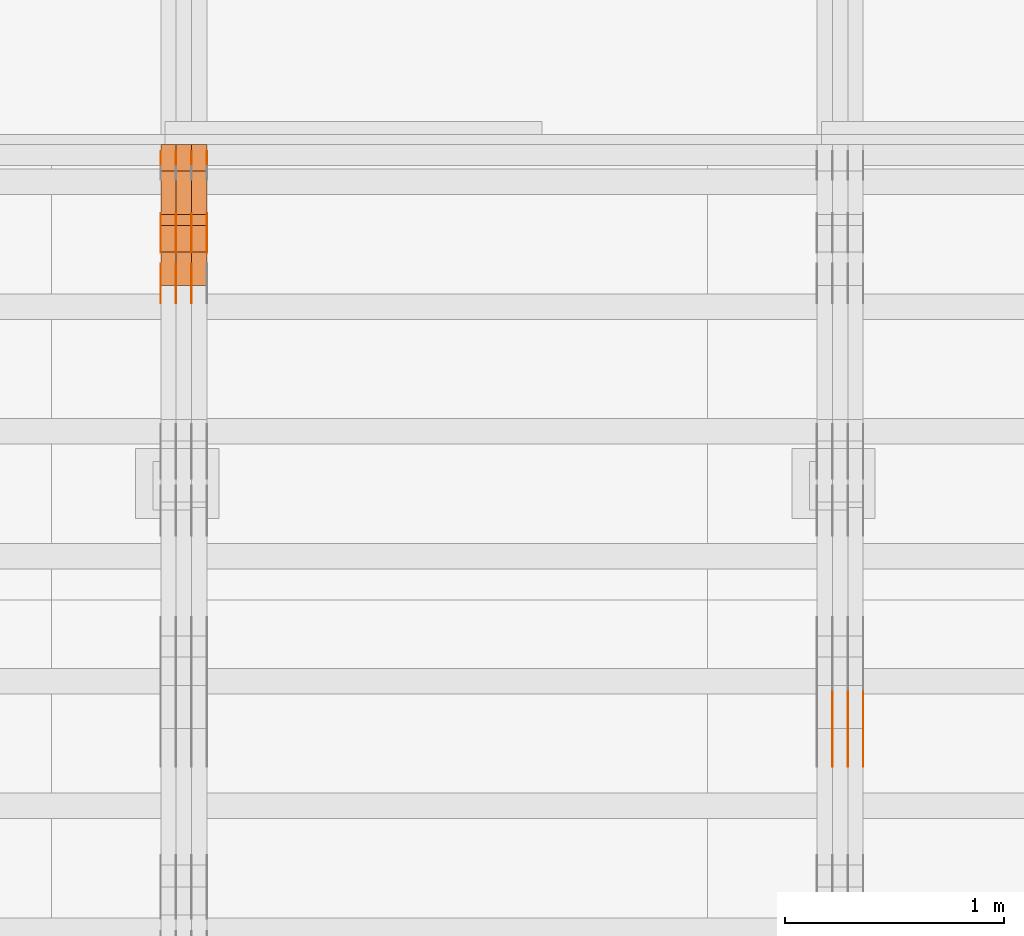
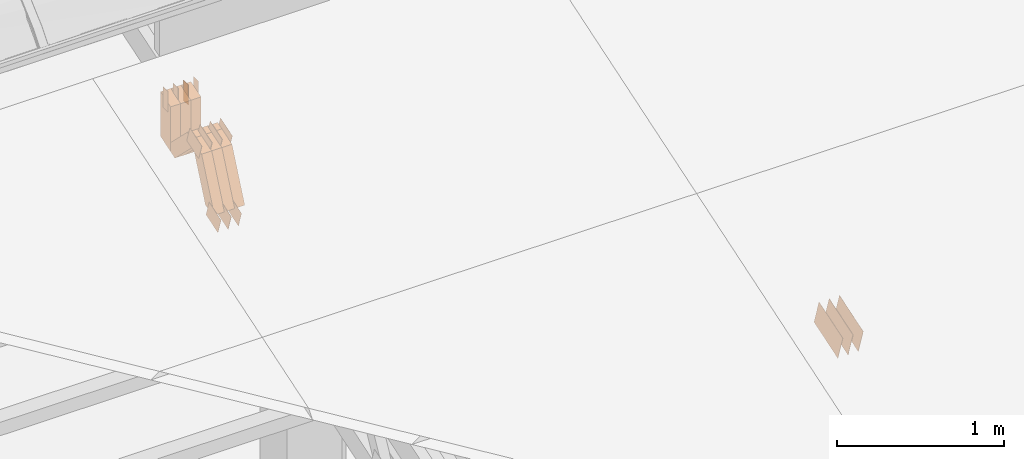
# One storey, part 296 of 385: 29 proxies.
"""IFC2X3 building model written with IfcOpenShell, lengths in millimetres."""

from ifc_helpers import new_model, entity, si_unit, converted_unit, derived_unit, direction, frame, origin, origin_2d_with_axis, place, context, subcontext, project, spatial, polyline, rectangle, outline, extrude, source, transform, mapped, material, type_object, type_shapes, element, save


model = new_model("IFC2X3")

# Units and contexts
model_context = context("Model", 3, precision=0.01, world=origin(), true_north=direction((6.12303176911189e-17, 1.0)))
body_context = subcontext(model_context, "Body", "Model", "MODEL_VIEW")
ifc_project = project(units=[si_unit("LENGTHUNIT", "METRE", prefix="MILLI"), si_unit("AREAUNIT", "SQUARE_METRE"), si_unit("VOLUMEUNIT", "CUBIC_METRE"), converted_unit("PLANEANGLEUNIT", "DEGREE", entity("IfcRatioMeasure", 0.0174532925199433), si_unit("PLANEANGLEUNIT", "RADIAN"), dimensions=[0, 0, 0, 0, 0, 0, 0]), si_unit("MASSUNIT", "GRAM", prefix="KILO"), derived_unit("MASSDENSITYUNIT", [(si_unit("MASSUNIT", "GRAM", prefix="KILO"), 1), (si_unit("LENGTHUNIT", "METRE"), -3)]), si_unit("TIMEUNIT", "SECOND"), si_unit("FREQUENCYUNIT", "HERTZ"), si_unit("THERMODYNAMICTEMPERATUREUNIT", "DEGREE_CELSIUS"), derived_unit("THERMALTRANSMITTANCEUNIT", [(si_unit("MASSUNIT", "GRAM", prefix="KILO"), 1), (si_unit("THERMODYNAMICTEMPERATUREUNIT", "KELVIN"), -1), (si_unit("TIMEUNIT", "SECOND"), -3)]), derived_unit("VOLUMETRICFLOWRATEUNIT", [(si_unit("LENGTHUNIT", "METRE"), 3), (si_unit("TIMEUNIT", "SECOND"), -1)]), si_unit("ELECTRICCURRENTUNIT", "AMPERE"), si_unit("ELECTRICVOLTAGEUNIT", "VOLT"), si_unit("POWERUNIT", "WATT"), si_unit("FORCEUNIT", "NEWTON", prefix="KILO"), si_unit("ILLUMINANCEUNIT", "LUX"), si_unit("LUMINOUSFLUXUNIT", "LUMEN"), si_unit("LUMINOUSINTENSITYUNIT", "CANDELA"), derived_unit("USERDEFINED", [(si_unit("MASSUNIT", "GRAM", prefix="KILO"), -1), (si_unit("LENGTHUNIT", "METRE"), -2), (si_unit("TIMEUNIT", "SECOND"), 3), (si_unit("LUMINOUSFLUXUNIT", "LUMEN"), 1)]), derived_unit("LINEARVELOCITYUNIT", [(si_unit("LENGTHUNIT", "METRE"), 1), (si_unit("TIMEUNIT", "SECOND"), -1)]), si_unit("PRESSUREUNIT", "PASCAL"), derived_unit("USERDEFINED", [(si_unit("LENGTHUNIT", "METRE"), -2), (si_unit("MASSUNIT", "GRAM", prefix="KILO"), 1), (si_unit("TIMEUNIT", "SECOND"), -2)])], contexts=[model_context])

# Site, building, storey
site_placement = place(None, origin())
site = spatial("IfcSite", under=ifc_project, at=site_placement, CompositionType="ELEMENT")
building_placement = place(site_placement, origin())
building = spatial("IfcBuilding", under=site, at=building_placement, CompositionType="ELEMENT")
storey_placement = place(building_placement, origin())
storey = spatial("IfcBuildingStorey", under=building, at=storey_placement, Name="Default", CompositionType="ELEMENT", Elevation=0.0)

# Proxies
ifc_material_1 = material(Name="IfcSurfaceStyle #552776")
building_element_proxy_type_1 = type_object("IfcBuildingElementProxyType", PredefinedType="NOTDEFINED", material=ifc_material_1)
shared_shape_1 = source(origin(), body_context, "Body", "SweptSolid", [
    extrude(outline(polyline([(-149.99966632326, -95.9999759039407), (149.999881095801, -95.9999759039407), (150.000557367591, 95.9999759039407), (-150.000772140132, 95.9999759039406), (-149.99966632326, -95.9999759039407)])), frame((150.000557367591, 96.0004291135906, 0.0), z_axis=(0.0, 0.0, 1.0), x_axis=(-1.0, 0.0, 0.0)), (0.0, 0.0, 1.0), 1.29999999999999),
])
type_shapes(building_element_proxy_type_1, [shared_shape_1])
proxy_1_placement = place(building_placement, frame((45386.3, 10934.7734375, 2766.8759765625), z_axis=(-1.0, 0.0, 0.0), x_axis=(0.0, 0.951056516295124, 0.309016994375039)))
element("IfcBuildingElementProxy", 1, at=proxy_1_placement, inside=storey, type_object=building_element_proxy_type_1, material=ifc_material_1, context=body_context, shape_type="MappedRepresentation", body=[
    mapped(shared_shape_1, transform((0.0, 0.0, 0.0), scale=1.0)),
])
ifc_material_2 = material(Name="IfcSurfaceStyle #552719")
building_element_proxy_type_2 = type_object("IfcBuildingElementProxyType", PredefinedType="NOTDEFINED", material=ifc_material_2)
shared_shape_2 = source(origin(), body_context, "Body", "SweptSolid", [
    extrude(outline(polyline([(-149.99966632326, -95.9999759039407), (149.999881095801, -95.9999759039407), (150.000557367591, 95.9999759039407), (-150.000772140132, 95.9999759039406), (-149.99966632326, -95.9999759039407)])), frame((150.000557367591, 96.0004291135906, 0.0), z_axis=(0.0, 0.0, 1.0), x_axis=(-1.0, 0.0, 0.0)), (0.0, 0.0, 1.0), 1.29999999999999),
])
type_shapes(building_element_proxy_type_2, [shared_shape_2])
proxy_2_placement = place(building_placement, frame((45315.0, 10934.7734375, 2766.8759765625), z_axis=(-1.0, 0.0, 0.0), x_axis=(0.0, 0.951056516295124, 0.309016994375039)))
element("IfcBuildingElementProxy", 2, at=proxy_2_placement, inside=storey, type_object=building_element_proxy_type_2, material=ifc_material_2, context=body_context, shape_type="MappedRepresentation", body=[
    mapped(shared_shape_2, transform((0.0, 0.0, 0.0), scale=1.0)),
])
ifc_material_3 = material(Name="IfcSurfaceStyle #552662")
building_element_proxy_type_3 = type_object("IfcBuildingElementProxyType", PredefinedType="NOTDEFINED", material=ifc_material_3)
shared_shape_3 = source(origin(), body_context, "Body", "SweptSolid", [
    extrude(outline(polyline([(-149.99966632326, -95.9999759039407), (149.999881095801, -95.9999759039407), (150.000557367591, 95.9999759039407), (-150.000772140132, 95.9999759039406), (-149.99966632326, -95.9999759039407)])), frame((150.000557367591, 96.0004291135906, 0.0), z_axis=(0.0, 0.0, 1.0), x_axis=(-1.0, 0.0, 0.0)), (0.0, 0.0, 1.0), 1.29999999999999),
])
type_shapes(building_element_proxy_type_3, [shared_shape_3])
proxy_3_placement = place(building_placement, frame((45316.3, 10934.7734375, 2766.8759765625), z_axis=(-1.0, 0.0, 0.0), x_axis=(0.0, 0.951056516295124, 0.309016994375039)))
element("IfcBuildingElementProxy", 3, at=proxy_3_placement, inside=storey, type_object=building_element_proxy_type_3, material=ifc_material_3, context=body_context, shape_type="MappedRepresentation", body=[
    mapped(shared_shape_3, transform((0.0, 0.0, 0.0), scale=1.0)),
])
ifc_material_4 = material(Name="IfcSurfaceStyle #552605")
building_element_proxy_type_4 = type_object("IfcBuildingElementProxyType", PredefinedType="NOTDEFINED", material=ifc_material_4)
shared_shape_4 = source(origin(), body_context, "Body", "SweptSolid", [
    extrude(outline(polyline([(-149.99966632326, -95.9999759039407), (149.999881095801, -95.9999759039407), (150.000557367591, 95.9999759039407), (-150.000772140132, 95.9999759039406), (-149.99966632326, -95.9999759039407)])), frame((150.000557367591, 96.0004291135906, 0.0), z_axis=(0.0, 0.0, 1.0), x_axis=(-1.0, 0.0, 0.0)), (0.0, 0.0, 1.0), 1.29999999999998),
])
type_shapes(building_element_proxy_type_4, [shared_shape_4])
proxy_4_placement = place(building_placement, frame((45245.0, 10934.7734375, 2766.8759765625), z_axis=(-1.0, 0.0, 0.0), x_axis=(0.0, 0.951056516295124, 0.309016994375039)))
element("IfcBuildingElementProxy", 4, at=proxy_4_placement, inside=storey, type_object=building_element_proxy_type_4, material=ifc_material_4, context=body_context, shape_type="MappedRepresentation", body=[
    mapped(shared_shape_4, transform((0.0, 0.0, 0.0), scale=1.0)),
])
ifc_material_5 = material(Name="IfcSurfaceStyle #518572")
building_element_proxy_type_5 = type_object("IfcBuildingElementProxyType", PredefinedType="NOTDEFINED", material=ifc_material_5)
shared_shape_5 = source(origin(), body_context, "Body", "SweptSolid", [
    extrude(outline(polyline([(-75.0003398116828, -59.9998507501386), (75.0003249421766, -59.9998507501386), (75.0003398116837, 59.9998507501387), (-75.0003249421775, 59.9998507501387), (-75.0003398116828, -59.9998507501386)])), frame((75.0003398116837, 60.0000773549637, 0.0), z_axis=(0.0, 0.0, 1.0), x_axis=(-1.0, 0.0, 0.0)), (0.0, 0.0, 1.0), 1.3),
])
type_shapes(building_element_proxy_type_5, [shared_shape_5])
proxy_5_placement = place(building_placement, frame((42316.3, 13054.73046875, 3417.8388671875), z_axis=(-1.0, 0.0, 0.0), x_axis=(0.0, 0.951056516295124, 0.309016994375039)))
element("IfcBuildingElementProxy", 5, at=proxy_5_placement, inside=storey, type_object=building_element_proxy_type_5, material=ifc_material_5, context=body_context, shape_type="MappedRepresentation", body=[
    mapped(shared_shape_5, transform((0.0, 0.0, 0.0), scale=1.0)),
])
ifc_material_6 = material(Name="IfcSurfaceStyle #518515")
building_element_proxy_type_6 = type_object("IfcBuildingElementProxyType", PredefinedType="NOTDEFINED", material=ifc_material_6)
shared_shape_6 = source(origin(), body_context, "Body", "SweptSolid", [
    extrude(outline(polyline([(-75.0003398116828, -59.9998507501386), (75.0003249421766, -59.9998507501386), (75.0003398116837, 59.9998507501387), (-75.0003249421775, 59.9998507501387), (-75.0003398116828, -59.9998507501386)])), frame((75.0003398116837, 60.0000773549637, 0.0), z_axis=(0.0, 0.0, 1.0), x_axis=(-1.0, 0.0, 0.0)), (0.0, 0.0, 1.0), 1.29999999999999),
])
type_shapes(building_element_proxy_type_6, [shared_shape_6])
proxy_6_placement = place(building_placement, frame((42245.0, 13054.73046875, 3417.8388671875), z_axis=(-1.0, 0.0, 0.0), x_axis=(0.0, 0.951056516295124, 0.309016994375039)))
element("IfcBuildingElementProxy", 6, at=proxy_6_placement, inside=storey, type_object=building_element_proxy_type_6, material=ifc_material_6, context=body_context, shape_type="MappedRepresentation", body=[
    mapped(shared_shape_6, transform((0.0, 0.0, 0.0), scale=1.0)),
])
ifc_material_7 = material(Name="IfcSurfaceStyle #518458")
building_element_proxy_type_7 = type_object("IfcBuildingElementProxyType", PredefinedType="NOTDEFINED", material=ifc_material_7)
shared_shape_7 = source(origin(), body_context, "Body", "SweptSolid", [
    extrude(outline(polyline([(-75.0003398116828, -59.9998507501386), (75.0003249421766, -59.9998507501386), (75.0003398116837, 59.9998507501387), (-75.0003249421775, 59.9998507501387), (-75.0003398116828, -59.9998507501386)])), frame((75.0003398116837, 60.0000773549637, 0.0), z_axis=(0.0, 0.0, 1.0), x_axis=(-1.0, 0.0, 0.0)), (0.0, 0.0, 1.0), 1.29999999999999),
])
type_shapes(building_element_proxy_type_7, [shared_shape_7])
proxy_7_placement = place(building_placement, frame((42246.3, 13054.73046875, 3417.8388671875), z_axis=(-1.0, 0.0, 0.0), x_axis=(0.0, 0.951056516295124, 0.309016994375039)))
element("IfcBuildingElementProxy", 7, at=proxy_7_placement, inside=storey, type_object=building_element_proxy_type_7, material=ifc_material_7, context=body_context, shape_type="MappedRepresentation", body=[
    mapped(shared_shape_7, transform((0.0, 0.0, 0.0), scale=1.0)),
])
ifc_material_8 = material(Name="IfcSurfaceStyle #518401")
building_element_proxy_type_8 = type_object("IfcBuildingElementProxyType", PredefinedType="NOTDEFINED", material=ifc_material_8)
shared_shape_8 = source(origin(), body_context, "Body", "SweptSolid", [
    extrude(outline(polyline([(-75.0003398116828, -59.9998507501386), (75.0003249421766, -59.9998507501386), (75.0003398116837, 59.9998507501387), (-75.0003249421775, 59.9998507501387), (-75.0003398116828, -59.9998507501386)])), frame((75.0003398116837, 60.0000773549637, 0.0), z_axis=(0.0, 0.0, 1.0), x_axis=(-1.0, 0.0, 0.0)), (0.0, 0.0, 1.0), 1.29999999999999),
])
type_shapes(building_element_proxy_type_8, [shared_shape_8])
proxy_8_placement = place(building_placement, frame((42175.0, 13054.73046875, 3417.8388671875), z_axis=(-1.0, 0.0, 0.0), x_axis=(0.0, 0.951056516295124, 0.309016994375039)))
element("IfcBuildingElementProxy", 8, at=proxy_8_placement, inside=storey, type_object=building_element_proxy_type_8, material=ifc_material_8, context=body_context, shape_type="MappedRepresentation", body=[
    mapped(shared_shape_8, transform((0.0, 0.0, 0.0), scale=1.0)),
])
ifc_material_9 = material(Name="IfcSurfaceStyle #510820")
building_element_proxy_type_9 = type_object("IfcBuildingElementProxyType", PredefinedType="NOTDEFINED", material=ifc_material_9)
shared_shape_9 = source(origin(), body_context, "Body", "SweptSolid", [
    extrude(outline(polyline([(-74.999875428623, -60.0000016373506), (74.9998605591059, -60.0000016373506), (74.9998754286239, 60.0000016373506), (-74.9998605591068, 60.0000016373506), (-74.999875428623, -60.0000016373506)])), frame((75.0002691827262, 60.0000190504561, 0.0), z_axis=(0.0, 0.0, 1.0), x_axis=(-1.0, 0.0, 0.0)), (0.0, 0.0, 1.0), 1.3),
])
type_shapes(building_element_proxy_type_9, [shared_shape_9])
proxy_9_placement = place(building_placement, frame((42386.3, 13285.0865109705, 3819.37496637467), z_axis=(-1.0, 0.0, 0.0), x_axis=(0.0, 0.951056516295154, 0.309016994374948)))
element("IfcBuildingElementProxy", 9, at=proxy_9_placement, inside=storey, type_object=building_element_proxy_type_9, material=ifc_material_9, context=body_context, shape_type="MappedRepresentation", body=[
    mapped(shared_shape_9, transform((0.0, 0.0, 0.0), scale=1.0)),
])
ifc_material_10 = material(Name="IfcSurfaceStyle #510763")
building_element_proxy_type_10 = type_object("IfcBuildingElementProxyType", PredefinedType="NOTDEFINED", material=ifc_material_10)
shared_shape_10 = source(origin(), body_context, "Body", "SweptSolid", [
    extrude(outline(polyline([(-74.999875428623, -60.0000016373506), (74.9998605591059, -60.0000016373506), (74.9998754286239, 60.0000016373506), (-74.9998605591068, 60.0000016373506), (-74.999875428623, -60.0000016373506)])), frame((75.0002691827262, 60.0000190504561, 0.0), z_axis=(0.0, 0.0, 1.0), x_axis=(-1.0, 0.0, 0.0)), (0.0, 0.0, 1.0), 1.3),
])
type_shapes(building_element_proxy_type_10, [shared_shape_10])
proxy_10_placement = place(building_placement, frame((42315.0, 13285.0865109705, 3819.37496637467), z_axis=(-1.0, 0.0, 0.0), x_axis=(0.0, 0.951056516295154, 0.309016994374948)))
element("IfcBuildingElementProxy", 10, at=proxy_10_placement, inside=storey, type_object=building_element_proxy_type_10, material=ifc_material_10, context=body_context, shape_type="MappedRepresentation", body=[
    mapped(shared_shape_10, transform((0.0, 0.0, 0.0), scale=1.0)),
])
ifc_material_11 = material(Name="IfcSurfaceStyle #510706")
building_element_proxy_type_11 = type_object("IfcBuildingElementProxyType", PredefinedType="NOTDEFINED", material=ifc_material_11)
shared_shape_11 = source(origin(), body_context, "Body", "SweptSolid", [
    extrude(outline(polyline([(-74.999875428623, -60.0000016373506), (74.9998605591059, -60.0000016373506), (74.9998754286239, 60.0000016373506), (-74.9998605591068, 60.0000016373506), (-74.999875428623, -60.0000016373506)])), frame((75.0002691827262, 60.0000190504561, 0.0), z_axis=(0.0, 0.0, 1.0), x_axis=(-1.0, 0.0, 0.0)), (0.0, 0.0, 1.0), 1.3),
])
type_shapes(building_element_proxy_type_11, [shared_shape_11])
proxy_11_placement = place(building_placement, frame((42316.3, 13285.0865109705, 3819.37496637467), z_axis=(-1.0, 0.0, 0.0), x_axis=(0.0, 0.951056516295154, 0.309016994374948)))
element("IfcBuildingElementProxy", 11, at=proxy_11_placement, inside=storey, type_object=building_element_proxy_type_11, material=ifc_material_11, context=body_context, shape_type="MappedRepresentation", body=[
    mapped(shared_shape_11, transform((0.0, 0.0, 0.0), scale=1.0)),
])
ifc_material_12 = material(Name="IfcSurfaceStyle #510649")
building_element_proxy_type_12 = type_object("IfcBuildingElementProxyType", PredefinedType="NOTDEFINED", material=ifc_material_12)
shared_shape_12 = source(origin(), body_context, "Body", "SweptSolid", [
    extrude(outline(polyline([(-74.999875428623, -60.0000016373506), (74.9998605591059, -60.0000016373506), (74.9998754286239, 60.0000016373506), (-74.9998605591068, 60.0000016373506), (-74.999875428623, -60.0000016373506)])), frame((75.0002691827262, 60.0000190504561, 0.0), z_axis=(0.0, 0.0, 1.0), x_axis=(-1.0, 0.0, 0.0)), (0.0, 0.0, 1.0), 1.29999999999999),
])
type_shapes(building_element_proxy_type_12, [shared_shape_12])
proxy_12_placement = place(building_placement, frame((42245.0, 13285.0865109705, 3819.37496637467), z_axis=(-1.0, 0.0, 0.0), x_axis=(0.0, 0.951056516295154, 0.309016994374948)))
element("IfcBuildingElementProxy", 12, at=proxy_12_placement, inside=storey, type_object=building_element_proxy_type_12, material=ifc_material_12, context=body_context, shape_type="MappedRepresentation", body=[
    mapped(shared_shape_12, transform((0.0, 0.0, 0.0), scale=1.0)),
])
ifc_material_13 = material(Name="IfcSurfaceStyle #510592")
building_element_proxy_type_13 = type_object("IfcBuildingElementProxyType", PredefinedType="NOTDEFINED", material=ifc_material_13)
shared_shape_13 = source(origin(), body_context, "Body", "SweptSolid", [
    extrude(outline(polyline([(-74.999875428623, -60.0000016373506), (74.9998605591059, -60.0000016373506), (74.9998754286239, 60.0000016373506), (-74.9998605591068, 60.0000016373506), (-74.999875428623, -60.0000016373506)])), frame((75.0002691827262, 60.0000190504561, 0.0), z_axis=(0.0, 0.0, 1.0), x_axis=(-1.0, 0.0, 0.0)), (0.0, 0.0, 1.0), 1.29999999999999),
])
type_shapes(building_element_proxy_type_13, [shared_shape_13])
proxy_13_placement = place(building_placement, frame((42246.3, 13285.0865109705, 3819.37496637467), z_axis=(-1.0, 0.0, 0.0), x_axis=(0.0, 0.951056516295154, 0.309016994374948)))
element("IfcBuildingElementProxy", 13, at=proxy_13_placement, inside=storey, type_object=building_element_proxy_type_13, material=ifc_material_13, context=body_context, shape_type="MappedRepresentation", body=[
    mapped(shared_shape_13, transform((0.0, 0.0, 0.0), scale=1.0)),
])
ifc_material_14 = material(Name="IfcSurfaceStyle #510535")
building_element_proxy_type_14 = type_object("IfcBuildingElementProxyType", PredefinedType="NOTDEFINED", material=ifc_material_14)
shared_shape_14 = source(origin(), body_context, "Body", "SweptSolid", [
    extrude(outline(polyline([(-74.999875428623, -60.0000016373506), (74.9998605591059, -60.0000016373506), (74.9998754286239, 60.0000016373506), (-74.9998605591068, 60.0000016373506), (-74.999875428623, -60.0000016373506)])), frame((75.0002691827262, 60.0000190504561, 0.0), z_axis=(0.0, 0.0, 1.0), x_axis=(-1.0, 0.0, 0.0)), (0.0, 0.0, 1.0), 1.29999999999999),
])
type_shapes(building_element_proxy_type_14, [shared_shape_14])
proxy_14_placement = place(building_placement, frame((42175.0, 13285.0865109705, 3819.37496637467), z_axis=(-1.0, 0.0, 0.0), x_axis=(0.0, 0.951056516295154, 0.309016994374948)))
element("IfcBuildingElementProxy", 14, at=proxy_14_placement, inside=storey, type_object=building_element_proxy_type_14, material=ifc_material_14, context=body_context, shape_type="MappedRepresentation", body=[
    mapped(shared_shape_14, transform((0.0, 0.0, 0.0), scale=1.0)),
])
ifc_material_15 = material(Name="IfcSurfaceStyle #510136")
building_element_proxy_type_15 = type_object("IfcBuildingElementProxyType", PredefinedType="NOTDEFINED", material=ifc_material_15)
shared_shape_15 = source(origin(), body_context, "Body", "SweptSolid", [
    extrude(rectangle(XDim=150.0, YDim=60.0, at=origin_2d_with_axis()), frame((75.0000705696166, 30.0, 0.0), z_axis=(0.0, 0.0, 1.0), x_axis=(-1.0, 0.0, 0.0)), (0.0, 0.0, 1.0), 1.3),
])
type_shapes(building_element_proxy_type_15, [shared_shape_15])
proxy_15_placement = place(building_placement, frame((42386.3, 13750.0, 3972.59919166337), z_axis=(-1.0, 0.0, 0.0), x_axis=(0.0, 0.0, -1.0)))
element("IfcBuildingElementProxy", 15, at=proxy_15_placement, inside=storey, type_object=building_element_proxy_type_15, material=ifc_material_15, context=body_context, shape_type="MappedRepresentation", body=[
    mapped(shared_shape_15, transform((0.0, 0.0, 0.0), scale=1.0)),
])
ifc_material_16 = material(Name="IfcSurfaceStyle #510079")
building_element_proxy_type_16 = type_object("IfcBuildingElementProxyType", PredefinedType="NOTDEFINED", material=ifc_material_16)
shared_shape_16 = source(origin(), body_context, "Body", "SweptSolid", [
    extrude(rectangle(XDim=150.0, YDim=60.0, at=origin_2d_with_axis()), frame((75.0000705696166, 30.0, 0.0), z_axis=(0.0, 0.0, 1.0), x_axis=(-1.0, 0.0, 0.0)), (0.0, 0.0, 1.0), 1.3),
])
type_shapes(building_element_proxy_type_16, [shared_shape_16])
proxy_16_placement = place(building_placement, frame((42315.0, 13750.0, 3972.59919166337), z_axis=(-1.0, 0.0, 0.0), x_axis=(0.0, 0.0, -1.0)))
element("IfcBuildingElementProxy", 16, at=proxy_16_placement, inside=storey, type_object=building_element_proxy_type_16, material=ifc_material_16, context=body_context, shape_type="MappedRepresentation", body=[
    mapped(shared_shape_16, transform((0.0, 0.0, 0.0), scale=1.0)),
])
ifc_material_17 = material(Name="IfcSurfaceStyle #510022")
building_element_proxy_type_17 = type_object("IfcBuildingElementProxyType", PredefinedType="NOTDEFINED", material=ifc_material_17)
shared_shape_17 = source(origin(), body_context, "Body", "SweptSolid", [
    extrude(rectangle(XDim=150.0, YDim=60.0, at=origin_2d_with_axis()), frame((75.0000705696166, 30.0, 0.0), z_axis=(0.0, 0.0, 1.0), x_axis=(-1.0, 0.0, 0.0)), (0.0, 0.0, 1.0), 1.3),
])
type_shapes(building_element_proxy_type_17, [shared_shape_17])
proxy_17_placement = place(building_placement, frame((42316.3, 13750.0, 3972.59919166337), z_axis=(-1.0, 0.0, 0.0), x_axis=(0.0, 0.0, -1.0)))
element("IfcBuildingElementProxy", 17, at=proxy_17_placement, inside=storey, type_object=building_element_proxy_type_17, material=ifc_material_17, context=body_context, shape_type="MappedRepresentation", body=[
    mapped(shared_shape_17, transform((0.0, 0.0, 0.0), scale=1.0)),
])
ifc_material_18 = material(Name="IfcSurfaceStyle #509965")
building_element_proxy_type_18 = type_object("IfcBuildingElementProxyType", PredefinedType="NOTDEFINED", material=ifc_material_18)
shared_shape_18 = source(origin(), body_context, "Body", "SweptSolid", [
    extrude(rectangle(XDim=150.0, YDim=60.0, at=origin_2d_with_axis()), frame((75.0000705696166, 30.0, 0.0), z_axis=(0.0, 0.0, 1.0), x_axis=(-1.0, 0.0, 0.0)), (0.0, 0.0, 1.0), 1.29999999999999),
])
type_shapes(building_element_proxy_type_18, [shared_shape_18])
proxy_18_placement = place(building_placement, frame((42245.0, 13750.0, 3972.59919166337), z_axis=(-1.0, 0.0, 0.0), x_axis=(0.0, 0.0, -1.0)))
element("IfcBuildingElementProxy", 18, at=proxy_18_placement, inside=storey, type_object=building_element_proxy_type_18, material=ifc_material_18, context=body_context, shape_type="MappedRepresentation", body=[
    mapped(shared_shape_18, transform((0.0, 0.0, 0.0), scale=1.0)),
])
ifc_material_19 = material(Name="IfcSurfaceStyle #509908")
building_element_proxy_type_19 = type_object("IfcBuildingElementProxyType", PredefinedType="NOTDEFINED", material=ifc_material_19)
shared_shape_19 = source(origin(), body_context, "Body", "SweptSolid", [
    extrude(rectangle(XDim=150.0, YDim=60.0, at=origin_2d_with_axis()), frame((75.0000705696166, 30.0, 0.0), z_axis=(0.0, 0.0, 1.0), x_axis=(-1.0, 0.0, 0.0)), (0.0, 0.0, 1.0), 1.29999999999999),
])
type_shapes(building_element_proxy_type_19, [shared_shape_19])
proxy_19_placement = place(building_placement, frame((42246.3, 13750.0, 3972.59919166337), z_axis=(-1.0, 0.0, 0.0), x_axis=(0.0, 0.0, -1.0)))
element("IfcBuildingElementProxy", 19, at=proxy_19_placement, inside=storey, type_object=building_element_proxy_type_19, material=ifc_material_19, context=body_context, shape_type="MappedRepresentation", body=[
    mapped(shared_shape_19, transform((0.0, 0.0, 0.0), scale=1.0)),
])
ifc_material_20 = material(Name="IfcSurfaceStyle #509851")
building_element_proxy_type_20 = type_object("IfcBuildingElementProxyType", PredefinedType="NOTDEFINED", material=ifc_material_20)
shared_shape_20 = source(origin(), body_context, "Body", "SweptSolid", [
    extrude(rectangle(XDim=150.0, YDim=60.0, at=origin_2d_with_axis()), frame((75.0000705696166, 30.0, 0.0), z_axis=(0.0, 0.0, 1.0), x_axis=(-1.0, 0.0, 0.0)), (0.0, 0.0, 1.0), 1.29999999999999),
])
type_shapes(building_element_proxy_type_20, [shared_shape_20])
proxy_20_placement = place(building_placement, frame((42175.0, 13750.0, 3972.59919166337), z_axis=(-1.0, 0.0, 0.0), x_axis=(0.0, 0.0, -1.0)))
element("IfcBuildingElementProxy", 20, at=proxy_20_placement, inside=storey, type_object=building_element_proxy_type_20, material=ifc_material_20, context=body_context, shape_type="MappedRepresentation", body=[
    mapped(shared_shape_20, transform((0.0, 0.0, 0.0), scale=1.0)),
])
ifc_material_21 = material(Name="IfcSurfaceStyle #500650")
building_element_proxy_type_21 = type_object("IfcBuildingElementProxyType", Name="T1-W49 500648", PredefinedType="NOTDEFINED", material=ifc_material_21)
shared_shape_21 = source(origin(), body_context, "Body", "SweptSolid", [
    extrude(outline(polyline([(-155.175867306415, -47.4997478409253), (152.310664695054, -47.4997478409253), (170.496756790954, -6.14570120142345e-05), (145.70957993751, 47.4998092979374), (-133.37808995724, 47.4998092979373), (-179.963044159863, -6.14570120298391e-05), (-155.175867306415, -47.4997478409253)])), frame((170.496756790954, 47.5001152140455, 0.0), z_axis=(0.0, 0.0, 1.0), x_axis=(-1.0, 0.0, 0.0)), (0.0, 0.0, 1.0), 70.0),
])
type_shapes(building_element_proxy_type_21, [shared_shape_21])
proxy_21_placement = place(building_placement, frame((42385.0, 13443.048524104, 3830.71841973934), z_axis=(-1.0, 0.0, 0.0), x_axis=(0.0, 0.713950095632063, -0.700196587357413)))
element("IfcBuildingElementProxy", 21, at=proxy_21_placement, inside=storey, type_object=building_element_proxy_type_21, material=ifc_material_21, Name="T1-W49", context=body_context, shape_type="MappedRepresentation", body=[
    mapped(shared_shape_21, transform((0.0, 0.0, 0.0), scale=1.0)),
])
ifc_material_22 = material(Name="IfcSurfaceStyle #500575")
building_element_proxy_type_22 = type_object("IfcBuildingElementProxyType", Name="T1-W49 500573", PredefinedType="NOTDEFINED", material=ifc_material_22)
shared_shape_22 = source(origin(), body_context, "Body", "SweptSolid", [
    extrude(outline(polyline([(-155.175867306415, -47.4997478409253), (152.310664695054, -47.4997478409253), (170.496756790954, -6.14570120142345e-05), (145.70957993751, 47.4998092979374), (-133.37808995724, 47.4998092979373), (-179.963044159863, -6.14570120298391e-05), (-155.175867306415, -47.4997478409253)])), frame((170.496756790954, 47.5001152140455, 0.0), z_axis=(0.0, 0.0, 1.0), x_axis=(-1.0, 0.0, 0.0)), (0.0, 0.0, 1.0), 70.0),
])
type_shapes(building_element_proxy_type_22, [shared_shape_22])
proxy_22_placement = place(building_placement, frame((42315.0, 13443.048524104, 3830.71841973934), z_axis=(-1.0, 0.0, 0.0), x_axis=(0.0, 0.713950095632063, -0.700196587357413)))
element("IfcBuildingElementProxy", 22, at=proxy_22_placement, inside=storey, type_object=building_element_proxy_type_22, material=ifc_material_22, Name="T1-W49", context=body_context, shape_type="MappedRepresentation", body=[
    mapped(shared_shape_22, transform((0.0, 0.0, 0.0), scale=1.0)),
])
ifc_material_23 = material(Name="IfcSurfaceStyle #500500")
building_element_proxy_type_23 = type_object("IfcBuildingElementProxyType", Name="T1-W49 500498", PredefinedType="NOTDEFINED", material=ifc_material_23)
shared_shape_23 = source(origin(), body_context, "Body", "SweptSolid", [
    extrude(outline(polyline([(-155.175867306415, -47.4997478409253), (152.310664695054, -47.4997478409253), (170.496756790954, -6.14570120142345e-05), (145.70957993751, 47.4998092979374), (-133.37808995724, 47.4998092979373), (-179.963044159863, -6.14570120298391e-05), (-155.175867306415, -47.4997478409253)])), frame((170.496756790954, 47.5001152140455, 0.0), z_axis=(0.0, 0.0, 1.0), x_axis=(-1.0, 0.0, 0.0)), (0.0, 0.0, 1.0), 70.0),
])
type_shapes(building_element_proxy_type_23, [shared_shape_23])
proxy_23_placement = place(building_placement, frame((42245.0, 13443.048524104, 3830.71841973934), z_axis=(-1.0, 0.0, 0.0), x_axis=(0.0, 0.713950095632063, -0.700196587357413)))
element("IfcBuildingElementProxy", 23, at=proxy_23_placement, inside=storey, type_object=building_element_proxy_type_23, material=ifc_material_23, Name="T1-W49", context=body_context, shape_type="MappedRepresentation", body=[
    mapped(shared_shape_23, transform((0.0, 0.0, 0.0), scale=1.0)),
])
ifc_material_24 = material(Name="IfcSurfaceStyle #500200")
building_element_proxy_type_24 = type_object("IfcBuildingElementProxyType", Name="T1-W1 500198", PredefinedType="NOTDEFINED", material=ifc_material_24)
shared_shape_24 = source(origin(), body_context, "Body", "SweptSolid", [
    extrude(outline(polyline([(-182.839782714844, -60.0), (143.849426269531, -60.0), (182.839660644531, 60.0), (-143.849304199219, 60.0), (-182.839782714844, -60.0)])), frame((182.839674685549, 60.0, 0.0), z_axis=(0.0, 0.0, 1.0), x_axis=(-1.0, 0.0, 0.0)), (0.0, 0.0, 1.0), 70.0),
])
type_shapes(building_element_proxy_type_24, [shared_shape_24])
proxy_24_placement = place(building_placement, frame((42385.0, 13660.0, 3551.41502502148), z_axis=(-1.0, 0.0, 0.0), x_axis=(0.0, 0.0, 1.0)))
element("IfcBuildingElementProxy", 24, at=proxy_24_placement, inside=storey, type_object=building_element_proxy_type_24, material=ifc_material_24, Name="T1-W1", context=body_context, shape_type="MappedRepresentation", body=[
    mapped(shared_shape_24, transform((0.0, 0.0, 0.0), scale=1.0)),
])
ifc_material_25 = material(Name="IfcSurfaceStyle #500143")
building_element_proxy_type_25 = type_object("IfcBuildingElementProxyType", Name="T1-W1 500141", PredefinedType="NOTDEFINED", material=ifc_material_25)
shared_shape_25 = source(origin(), body_context, "Body", "SweptSolid", [
    extrude(outline(polyline([(-182.839782714844, -60.0), (143.849426269531, -60.0), (182.839660644531, 60.0), (-143.849304199219, 60.0), (-182.839782714844, -60.0)])), frame((182.839674685549, 60.0, 0.0), z_axis=(0.0, 0.0, 1.0), x_axis=(-1.0, 0.0, 0.0)), (0.0, 0.0, 1.0), 70.0),
])
type_shapes(building_element_proxy_type_25, [shared_shape_25])
proxy_25_placement = place(building_placement, frame((42315.0, 13660.0, 3551.41502502148), z_axis=(-1.0, 0.0, 0.0), x_axis=(0.0, 0.0, 1.0)))
element("IfcBuildingElementProxy", 25, at=proxy_25_placement, inside=storey, type_object=building_element_proxy_type_25, material=ifc_material_25, Name="T1-W1", context=body_context, shape_type="MappedRepresentation", body=[
    mapped(shared_shape_25, transform((0.0, 0.0, 0.0), scale=1.0)),
])
ifc_material_26 = material(Name="IfcSurfaceStyle #500086")
building_element_proxy_type_26 = type_object("IfcBuildingElementProxyType", Name="T1-W1 500084", PredefinedType="NOTDEFINED", material=ifc_material_26)
shared_shape_26 = source(origin(), body_context, "Body", "SweptSolid", [
    extrude(outline(polyline([(-182.839782714844, -60.0), (143.849426269531, -60.0), (182.839660644531, 60.0), (-143.849304199219, 60.0), (-182.839782714844, -60.0)])), frame((182.839674685549, 60.0, 0.0), z_axis=(0.0, 0.0, 1.0), x_axis=(-1.0, 0.0, 0.0)), (0.0, 0.0, 1.0), 70.0),
])
type_shapes(building_element_proxy_type_26, [shared_shape_26])
proxy_26_placement = place(building_placement, frame((42245.0, 13660.0, 3551.41502502148), z_axis=(-1.0, 0.0, 0.0), x_axis=(0.0, 0.0, 1.0)))
element("IfcBuildingElementProxy", 26, at=proxy_26_placement, inside=storey, type_object=building_element_proxy_type_26, material=ifc_material_26, Name="T1-W1", context=body_context, shape_type="MappedRepresentation", body=[
    mapped(shared_shape_26, transform((0.0, 0.0, 0.0), scale=1.0)),
])
ifc_material_27 = material(Name="IfcSurfaceStyle #499660")
building_element_proxy_type_27 = type_object("IfcBuildingElementProxyType", Name="T1-W42 499658", PredefinedType="NOTDEFINED", material=ifc_material_27)
shared_shape_27 = source(origin(), body_context, "Body", "SweptSolid", [
    extrude(outline(polyline([(-284.837590197601, -47.4997543607933), (129.95880168156, -47.4997543607933), (171.972324990451, 0.000162623346093338), (183.717007105413, 47.4996730491203), (-200.810543579822, 47.4996730491203), (-284.837590197601, -47.4997543607933)])), frame((183.717155718752, 47.4999821655365, 0.0), z_axis=(0.0, 0.0, 1.0), x_axis=(-1.0, 0.0, 0.0)), (0.0, 0.0, 1.0), 70.0),
])
type_shapes(building_element_proxy_type_27, [shared_shape_27])
proxy_27_placement = place(building_placement, frame((42385.0, 13135.8834463264, 3404.958483022), z_axis=(-1.0, 0.0, 0.0), x_axis=(0.0, 0.398630596470292, 0.917111578575769)))
element("IfcBuildingElementProxy", 27, at=proxy_27_placement, inside=storey, type_object=building_element_proxy_type_27, material=ifc_material_27, Name="T1-W42", context=body_context, shape_type="MappedRepresentation", body=[
    mapped(shared_shape_27, transform((0.0, 0.0, 0.0), scale=1.0)),
])
ifc_material_28 = material(Name="IfcSurfaceStyle #499594")
building_element_proxy_type_28 = type_object("IfcBuildingElementProxyType", Name="T1-W42 499592", PredefinedType="NOTDEFINED", material=ifc_material_28)
shared_shape_28 = source(origin(), body_context, "Body", "SweptSolid", [
    extrude(outline(polyline([(-284.837590197601, -47.4997543607933), (129.95880168156, -47.4997543607933), (171.972324990451, 0.000162623346093338), (183.717007105413, 47.4996730491203), (-200.810543579822, 47.4996730491203), (-284.837590197601, -47.4997543607933)])), frame((183.717155718752, 47.4999821655365, 0.0), z_axis=(0.0, 0.0, 1.0), x_axis=(-1.0, 0.0, 0.0)), (0.0, 0.0, 1.0), 70.0),
])
type_shapes(building_element_proxy_type_28, [shared_shape_28])
proxy_28_placement = place(building_placement, frame((42315.0, 13135.8834463264, 3404.958483022), z_axis=(-1.0, 0.0, 0.0), x_axis=(0.0, 0.398630596470292, 0.917111578575769)))
element("IfcBuildingElementProxy", 28, at=proxy_28_placement, inside=storey, type_object=building_element_proxy_type_28, material=ifc_material_28, Name="T1-W42", context=body_context, shape_type="MappedRepresentation", body=[
    mapped(shared_shape_28, transform((0.0, 0.0, 0.0), scale=1.0)),
])
ifc_material_29 = material(Name="IfcSurfaceStyle #499528")
building_element_proxy_type_29 = type_object("IfcBuildingElementProxyType", Name="T1-W42 499526", PredefinedType="NOTDEFINED", material=ifc_material_29)
shared_shape_29 = source(origin(), body_context, "Body", "SweptSolid", [
    extrude(outline(polyline([(-284.837590197601, -47.4997543607933), (129.95880168156, -47.4997543607933), (171.972324990451, 0.000162623346093338), (183.717007105413, 47.4996730491203), (-200.810543579822, 47.4996730491203), (-284.837590197601, -47.4997543607933)])), frame((183.717155718752, 47.4999821655365, 0.0), z_axis=(0.0, 0.0, 1.0), x_axis=(-1.0, 0.0, 0.0)), (0.0, 0.0, 1.0), 70.0),
])
type_shapes(building_element_proxy_type_29, [shared_shape_29])
proxy_29_placement = place(building_placement, frame((42245.0, 13135.8834463264, 3404.958483022), z_axis=(-1.0, 0.0, 0.0), x_axis=(0.0, 0.398630596470292, 0.917111578575769)))
element("IfcBuildingElementProxy", 29, at=proxy_29_placement, inside=storey, type_object=building_element_proxy_type_29, material=ifc_material_29, Name="T1-W42", context=body_context, shape_type="MappedRepresentation", body=[
    mapped(shared_shape_29, transform((0.0, 0.0, 0.0), scale=1.0)),
])

save(model, "model.ifc")
